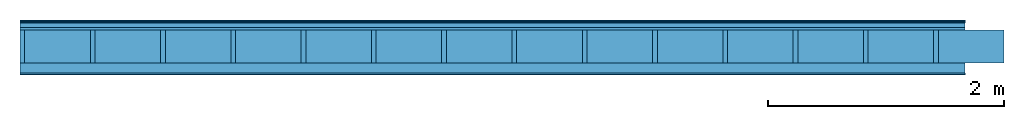
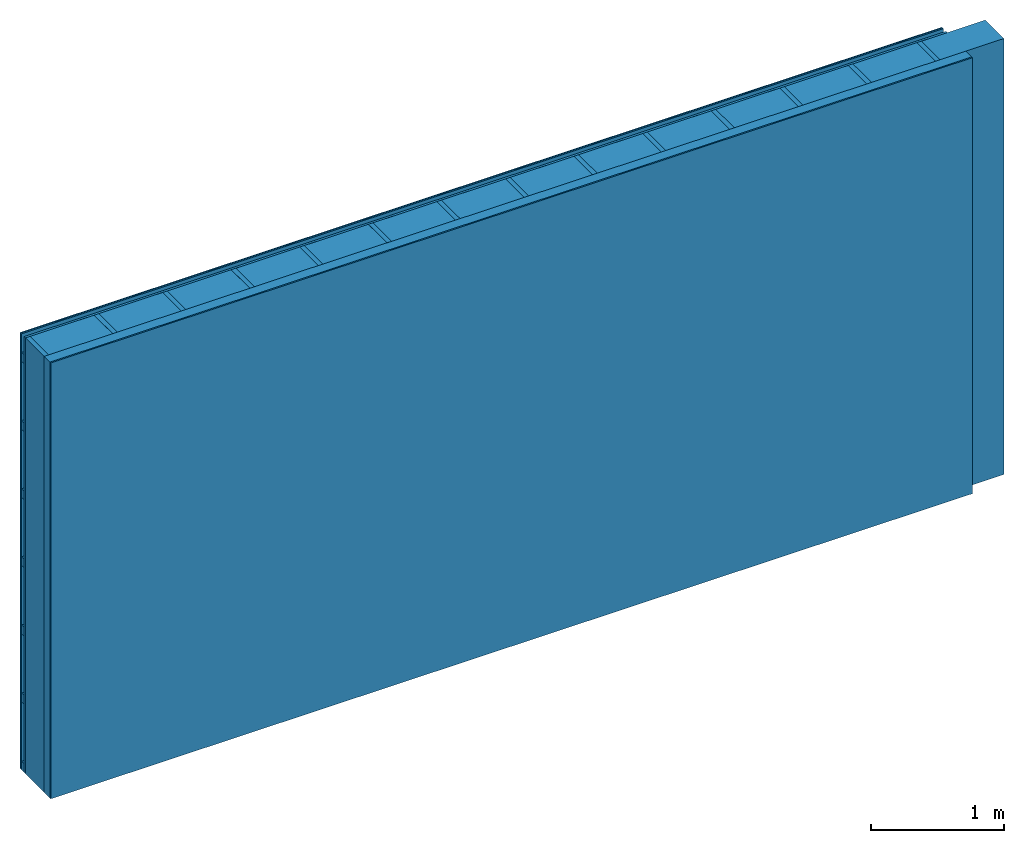
# One storey: 5 plates, 3 members, 1 element without a shape of its own.
"""IFC4 building model written with IfcOpenShell, lengths in metres."""

from ifc_helpers import new_model, si_unit, derived_unit, direction, frame, frame_2d, origin, origin_with_axes, place, context, project, spatial, rectangle, extrude, material, layer, layer_set, type_object, element, aggregate, save


model = new_model("IFC4")

# Units and contexts
plan_context = context("Plan", 3, precision=1e-05, world=origin(), true_north=direction((0.0, 1.0)))
model_context = context("Model", 3, precision=1e-05, world=origin(), true_north=direction((0.0, 1.0)))
ifc_project = project(units=[si_unit("LENGTHUNIT", "METRE"), derived_unit("SOUNDPRESSUREUNIT", [(si_unit("PRESSUREUNIT", "PASCAL", prefix="MICRO"), 0)]), si_unit("ENERGYUNIT", "JOULE", prefix="MEGA"), si_unit("MASSUNIT", "GRAM", prefix="KILO"), derived_unit("THERMALTRANSMITTANCEUNIT", [(si_unit("POWERUNIT", "WATT"), 1), (si_unit("AREAUNIT", "SQUARE_METRE"), -1), (si_unit("THERMODYNAMICTEMPERATUREUNIT", "KELVIN"), -1)]), derived_unit("AREADENSITYUNIT", [(si_unit("MASSUNIT", "GRAM", prefix="KILO"), 1), (si_unit("AREAUNIT", "SQUARE_METRE"), -1)]), derived_unit("USERDEFINED", [(si_unit("ENERGYUNIT", "JOULE", prefix="MEGA"), 1), (si_unit("AREAUNIT", "SQUARE_METRE"), -1)])], contexts=[plan_context, model_context])

# Site, building, storey
site = spatial("IfcSite", under=ifc_project)
building_placement = place(None, origin())
building = spatial("IfcBuilding", under=site, at=building_placement)
storey_placement = place(building_placement, origin())
storey = spatial("IfcBuildingStorey", under=building, at=storey_placement)

# Wall, members, plates
ifc_material_1 = material(Category="04.011")
ifc_layer_1 = layer(ifc_material_1, 0.01, Name="Surface 1")
ifc_material_2 = material(Name="mineral, cement-based building board", Category="03.003")
ifc_layer_2 = layer(ifc_material_2, 0.013, Name="Cover 1st layer")
ifc_layer_3 = layer(None, 0.04, Name="Battens / profiles (ventilation)")
ifc_material_3 = material(Category="10.009")
ifc_layer_4 = layer(ifc_material_3, 0.02, Name="outside 1st layer")
ifc_material_4 = material(Name="of the art")
ifc_layer_5 = layer(ifc_material_4, 0.0, Name="Bond")
ifc_layer_6 = layer(None, 0.28, Name="Support")
ifc_layer_7 = layer(ifc_material_4, 0.0, Name="Bond")
ifc_material_5 = material(Name="Solid timber panel")
ifc_layer_8 = layer(ifc_material_5, 0.087, Name="1st layer")
ifc_material_6 = material(Name="Plasterboard type A", Category="03.008")
ifc_layer_9 = layer(ifc_material_6, 0.0125, Name="Covering 1st layer")
ifc_material_7 = material(Name="joints", Category="04.017")
ifc_layer_10 = layer(ifc_material_7, 0.0, Name="Surface")
ifc_layer_set = layer_set([ifc_layer_1, ifc_layer_2, ifc_layer_3, ifc_layer_4, ifc_layer_5, ifc_layer_6, ifc_layer_7, ifc_layer_8, ifc_layer_9, ifc_layer_10])
wall_type = type_object("IfcWallType", Name="D0977", PredefinedType="NOTDEFINED", material=ifc_layer_set)
wall_placement = place(None, frame((0.0, 0.0, 0.0), z_axis=(0.0, -1.0, 0.0), x_axis=(1.0, 0.0, 0.0)))
wall = element("IfcWall", 1, at=wall_placement, inside=storey, type_object=wall_type, material=ifc_layer_set, Name="Wall #1")
ifc_material_8 = material()
member_1_placement = place(wall_placement, origin())
member_1 = element("IfcMember", 2, at=member_1_placement, material=ifc_material_8, Name="Battens / profiles (ventilation)", context=plan_context, shape_type="SweptSolid", body=[
    extrude(rectangle(XDim=0.08, YDim=0.04, at=frame_2d((0.04, 0.02), x_axis=(1.0, 0.0))), frame((0.0, 0.0, 0.023), z_axis=(1.0, 0.0, 0.0), x_axis=(0.0, 1.0, 0.0)), (0.0, 0.0, 1.0), 8.0),
    extrude(rectangle(XDim=0.08, YDim=0.04, at=frame_2d((0.04, 0.02), x_axis=(1.0, 0.0))), frame((0.0, 0.625, 0.023), z_axis=(1.0, 0.0, 0.0), x_axis=(0.0, 1.0, 0.0)), (0.0, 0.0, 1.0), 8.0),
    extrude(rectangle(XDim=0.08, YDim=0.04, at=frame_2d((0.04, 0.02), x_axis=(1.0, 0.0))), frame((0.0, 1.25, 0.023), z_axis=(1.0, 0.0, 0.0), x_axis=(0.0, 1.0, 0.0)), (0.0, 0.0, 1.0), 8.0),
    extrude(rectangle(XDim=0.08, YDim=0.04, at=frame_2d((0.04, 0.02), x_axis=(1.0, 0.0))), frame((0.0, 1.875, 0.023), z_axis=(1.0, 0.0, 0.0), x_axis=(0.0, 1.0, 0.0)), (0.0, 0.0, 1.0), 8.0),
    extrude(rectangle(XDim=0.08, YDim=0.04, at=frame_2d((0.04, 0.02), x_axis=(1.0, 0.0))), frame((0.0, 2.5, 0.023), z_axis=(1.0, 0.0, 0.0), x_axis=(0.0, 1.0, 0.0)), (0.0, 0.0, 1.0), 8.0),
    extrude(rectangle(XDim=0.08, YDim=0.04, at=frame_2d((0.04, 0.02), x_axis=(1.0, 0.0))), frame((0.0, 3.125, 0.023), z_axis=(1.0, 0.0, 0.0), x_axis=(0.0, 1.0, 0.0)), (0.0, 0.0, 1.0), 8.0),
    extrude(rectangle(XDim=0.08, YDim=0.04, at=frame_2d((0.04, 0.02), x_axis=(1.0, 0.0))), frame((0.0, 3.75, 0.023), z_axis=(1.0, 0.0, 0.0), x_axis=(0.0, 1.0, 0.0)), (0.0, 0.0, 1.0), 8.0),
])
ifc_material_9 = material()
member_2_placement = place(wall_placement, origin())
member_2 = element("IfcMember", 3, at=member_2_placement, material=ifc_material_9, Name="Support", context=plan_context, shape_type="SweptSolid", body=[
    extrude(rectangle(XDim=0.04, YDim=0.28, at=frame_2d((0.02, 0.14), x_axis=(1.0, 0.0))), frame((0.0, 4.0, 0.083), z_axis=(0.0, -1.0, 0.0), x_axis=(1.0, 0.0, 0.0)), (0.0, 0.0, 1.0), 4.0),
    extrude(rectangle(XDim=0.04, YDim=0.28, at=frame_2d((0.02, 0.14), x_axis=(1.0, 0.0))), frame((0.595, 4.0, 0.083), z_axis=(0.0, -1.0, 0.0), x_axis=(1.0, 0.0, 0.0)), (0.0, 0.0, 1.0), 4.0),
    extrude(rectangle(XDim=0.04, YDim=0.28, at=frame_2d((0.02, 0.14), x_axis=(1.0, 0.0))), frame((1.19, 4.0, 0.083), z_axis=(0.0, -1.0, 0.0), x_axis=(1.0, 0.0, 0.0)), (0.0, 0.0, 1.0), 4.0),
    extrude(rectangle(XDim=0.04, YDim=0.28, at=frame_2d((0.02, 0.14), x_axis=(1.0, 0.0))), frame((1.785, 4.0, 0.083), z_axis=(0.0, -1.0, 0.0), x_axis=(1.0, 0.0, 0.0)), (0.0, 0.0, 1.0), 4.0),
    extrude(rectangle(XDim=0.04, YDim=0.28, at=frame_2d((0.02, 0.14), x_axis=(1.0, 0.0))), frame((2.38, 4.0, 0.083), z_axis=(0.0, -1.0, 0.0), x_axis=(1.0, 0.0, 0.0)), (0.0, 0.0, 1.0), 4.0),
    extrude(rectangle(XDim=0.04, YDim=0.28, at=frame_2d((0.02, 0.14), x_axis=(1.0, 0.0))), frame((2.975, 4.0, 0.083), z_axis=(0.0, -1.0, 0.0), x_axis=(1.0, 0.0, 0.0)), (0.0, 0.0, 1.0), 4.0),
    extrude(rectangle(XDim=0.04, YDim=0.28, at=frame_2d((0.02, 0.14), x_axis=(1.0, 0.0))), frame((3.57, 4.0, 0.083), z_axis=(0.0, -1.0, 0.0), x_axis=(1.0, 0.0, 0.0)), (0.0, 0.0, 1.0), 4.0),
    extrude(rectangle(XDim=0.04, YDim=0.28, at=frame_2d((0.02, 0.14), x_axis=(1.0, 0.0))), frame((4.165, 4.0, 0.083), z_axis=(0.0, -1.0, 0.0), x_axis=(1.0, 0.0, 0.0)), (0.0, 0.0, 1.0), 4.0),
    extrude(rectangle(XDim=0.04, YDim=0.28, at=frame_2d((0.02, 0.14), x_axis=(1.0, 0.0))), frame((4.76, 4.0, 0.083), z_axis=(0.0, -1.0, 0.0), x_axis=(1.0, 0.0, 0.0)), (0.0, 0.0, 1.0), 4.0),
    extrude(rectangle(XDim=0.04, YDim=0.28, at=frame_2d((0.02, 0.14), x_axis=(1.0, 0.0))), frame((5.355, 4.0, 0.083), z_axis=(0.0, -1.0, 0.0), x_axis=(1.0, 0.0, 0.0)), (0.0, 0.0, 1.0), 4.0),
    extrude(rectangle(XDim=0.04, YDim=0.28, at=frame_2d((0.02, 0.14), x_axis=(1.0, 0.0))), frame((5.95, 4.0, 0.083), z_axis=(0.0, -1.0, 0.0), x_axis=(1.0, 0.0, 0.0)), (0.0, 0.0, 1.0), 4.0),
    extrude(rectangle(XDim=0.04, YDim=0.28, at=frame_2d((0.02, 0.14), x_axis=(1.0, 0.0))), frame((6.545, 4.0, 0.083), z_axis=(0.0, -1.0, 0.0), x_axis=(1.0, 0.0, 0.0)), (0.0, 0.0, 1.0), 4.0),
    extrude(rectangle(XDim=0.04, YDim=0.28, at=frame_2d((0.02, 0.14), x_axis=(1.0, 0.0))), frame((7.14, 4.0, 0.083), z_axis=(0.0, -1.0, 0.0), x_axis=(1.0, 0.0, 0.0)), (0.0, 0.0, 1.0), 4.0),
    extrude(rectangle(XDim=0.04, YDim=0.28, at=frame_2d((0.02, 0.14), x_axis=(1.0, 0.0))), frame((7.735, 4.0, 0.083), z_axis=(0.0, -1.0, 0.0), x_axis=(1.0, 0.0, 0.0)), (0.0, 0.0, 1.0), 4.0),
])
ifc_material_10 = material()
member_3_placement = place(wall_placement, origin())
member_3 = element("IfcMember", 4, at=member_3_placement, material=ifc_material_10, Name="Cavity", context=plan_context, shape_type="SweptSolid", body=[
    extrude(rectangle(XDim=0.555, YDim=0.28, at=frame_2d((0.2775, 0.14), x_axis=(1.0, 0.0))), frame((0.04, 4.0, 0.083), z_axis=(0.0, -1.0, 0.0), x_axis=(1.0, 0.0, 0.0)), (0.0, 0.0, 1.0), 4.0),
    extrude(rectangle(XDim=0.555, YDim=0.28, at=frame_2d((0.2775, 0.14), x_axis=(1.0, 0.0))), frame((0.635, 4.0, 0.083), z_axis=(0.0, -1.0, 0.0), x_axis=(1.0, 0.0, 0.0)), (0.0, 0.0, 1.0), 4.0),
    extrude(rectangle(XDim=0.555, YDim=0.28, at=frame_2d((0.2775, 0.14), x_axis=(1.0, 0.0))), frame((1.23, 4.0, 0.083), z_axis=(0.0, -1.0, 0.0), x_axis=(1.0, 0.0, 0.0)), (0.0, 0.0, 1.0), 4.0),
    extrude(rectangle(XDim=0.555, YDim=0.28, at=frame_2d((0.2775, 0.14), x_axis=(1.0, 0.0))), frame((1.825, 4.0, 0.083), z_axis=(0.0, -1.0, 0.0), x_axis=(1.0, 0.0, 0.0)), (0.0, 0.0, 1.0), 4.0),
    extrude(rectangle(XDim=0.555, YDim=0.28, at=frame_2d((0.2775, 0.14), x_axis=(1.0, 0.0))), frame((2.42, 4.0, 0.083), z_axis=(0.0, -1.0, 0.0), x_axis=(1.0, 0.0, 0.0)), (0.0, 0.0, 1.0), 4.0),
    extrude(rectangle(XDim=0.555, YDim=0.28, at=frame_2d((0.2775, 0.14), x_axis=(1.0, 0.0))), frame((3.015, 4.0, 0.083), z_axis=(0.0, -1.0, 0.0), x_axis=(1.0, 0.0, 0.0)), (0.0, 0.0, 1.0), 4.0),
    extrude(rectangle(XDim=0.555, YDim=0.28, at=frame_2d((0.2775, 0.14), x_axis=(1.0, 0.0))), frame((3.61, 4.0, 0.083), z_axis=(0.0, -1.0, 0.0), x_axis=(1.0, 0.0, 0.0)), (0.0, 0.0, 1.0), 4.0),
    extrude(rectangle(XDim=0.555, YDim=0.28, at=frame_2d((0.2775, 0.14), x_axis=(1.0, 0.0))), frame((4.205, 4.0, 0.083), z_axis=(0.0, -1.0, 0.0), x_axis=(1.0, 0.0, 0.0)), (0.0, 0.0, 1.0), 4.0),
    extrude(rectangle(XDim=0.555, YDim=0.28, at=frame_2d((0.2775, 0.14), x_axis=(1.0, 0.0))), frame((4.8, 4.0, 0.083), z_axis=(0.0, -1.0, 0.0), x_axis=(1.0, 0.0, 0.0)), (0.0, 0.0, 1.0), 4.0),
    extrude(rectangle(XDim=0.555, YDim=0.28, at=frame_2d((0.2775, 0.14), x_axis=(1.0, 0.0))), frame((5.395, 4.0, 0.083), z_axis=(0.0, -1.0, 0.0), x_axis=(1.0, 0.0, 0.0)), (0.0, 0.0, 1.0), 4.0),
    extrude(rectangle(XDim=0.555, YDim=0.28, at=frame_2d((0.2775, 0.14), x_axis=(1.0, 0.0))), frame((5.99, 4.0, 0.083), z_axis=(0.0, -1.0, 0.0), x_axis=(1.0, 0.0, 0.0)), (0.0, 0.0, 1.0), 4.0),
    extrude(rectangle(XDim=0.555, YDim=0.28, at=frame_2d((0.2775, 0.14), x_axis=(1.0, 0.0))), frame((6.585, 4.0, 0.083), z_axis=(0.0, -1.0, 0.0), x_axis=(1.0, 0.0, 0.0)), (0.0, 0.0, 1.0), 4.0),
    extrude(rectangle(XDim=0.555, YDim=0.28, at=frame_2d((0.2775, 0.14), x_axis=(1.0, 0.0))), frame((7.18, 4.0, 0.083), z_axis=(0.0, -1.0, 0.0), x_axis=(1.0, 0.0, 0.0)), (0.0, 0.0, 1.0), 4.0),
    extrude(rectangle(XDim=0.555, YDim=0.28, at=frame_2d((0.2775, 0.14), x_axis=(1.0, 0.0))), frame((7.775, 4.0, 0.083), z_axis=(0.0, -1.0, 0.0), x_axis=(1.0, 0.0, 0.0)), (0.0, 0.0, 1.0), 4.0),
])
plate_1_placement = place(wall_placement, origin())
plate_1 = element("IfcPlate", 5, at=plate_1_placement, material=ifc_material_1, Name="Surface 1", context=plan_context, shape_type="SweptSolid", body=[
    extrude(rectangle(XDim=8.0, YDim=4.0, at=frame_2d((4.0, 2.0), x_axis=(1.0, 0.0))), origin_with_axes(), (0.0, 0.0, 1.0), 0.01),
])
plate_2_placement = place(wall_placement, origin())
plate_2 = element("IfcPlate", 6, at=plate_2_placement, material=ifc_material_2, Name="Cover 1st layer", context=plan_context, shape_type="SweptSolid", body=[
    extrude(rectangle(XDim=8.0, YDim=4.0, at=frame_2d((4.0, 2.0), x_axis=(1.0, 0.0))), frame((0.0, 0.0, 0.01), z_axis=(0.0, 0.0, 1.0), x_axis=(1.0, 0.0, 0.0)), (0.0, 0.0, 1.0), 0.013),
])
plate_3_placement = place(wall_placement, origin())
plate_3 = element("IfcPlate", 7, at=plate_3_placement, material=ifc_material_3, Name="outside 1st layer", context=plan_context, shape_type="SweptSolid", body=[
    extrude(rectangle(XDim=8.0, YDim=4.0, at=frame_2d((4.0, 2.0), x_axis=(1.0, 0.0))), frame((0.0, 0.0, 0.063), z_axis=(0.0, 0.0, 1.0), x_axis=(1.0, 0.0, 0.0)), (0.0, 0.0, 1.0), 0.02),
])
plate_4_placement = place(wall_placement, origin())
plate_4 = element("IfcPlate", 8, at=plate_4_placement, material=ifc_material_5, Name="1st layer", context=plan_context, shape_type="SweptSolid", body=[
    extrude(rectangle(XDim=8.0, YDim=4.0, at=frame_2d((4.0, 2.0), x_axis=(1.0, 0.0))), frame((0.0, 0.0, 0.363), z_axis=(0.0, 0.0, 1.0), x_axis=(1.0, 0.0, 0.0)), (0.0, 0.0, 1.0), 0.087),
])
plate_5_placement = place(wall_placement, origin())
plate_5 = element("IfcPlate", 9, at=plate_5_placement, material=ifc_material_6, Name="Covering 1st layer", context=plan_context, shape_type="SweptSolid", body=[
    extrude(rectangle(XDim=8.0, YDim=4.0, at=frame_2d((4.0, 2.0), x_axis=(1.0, 0.0))), frame((0.0, 0.0, 0.45), z_axis=(0.0, 0.0, 1.0), x_axis=(1.0, 0.0, 0.0)), (0.0, 0.0, 1.0), 0.0125),
])
aggregate(wall, [plate_1, plate_2, member_1, plate_3, member_2, member_3, plate_4, plate_5])

save(model, "model.ifc")
